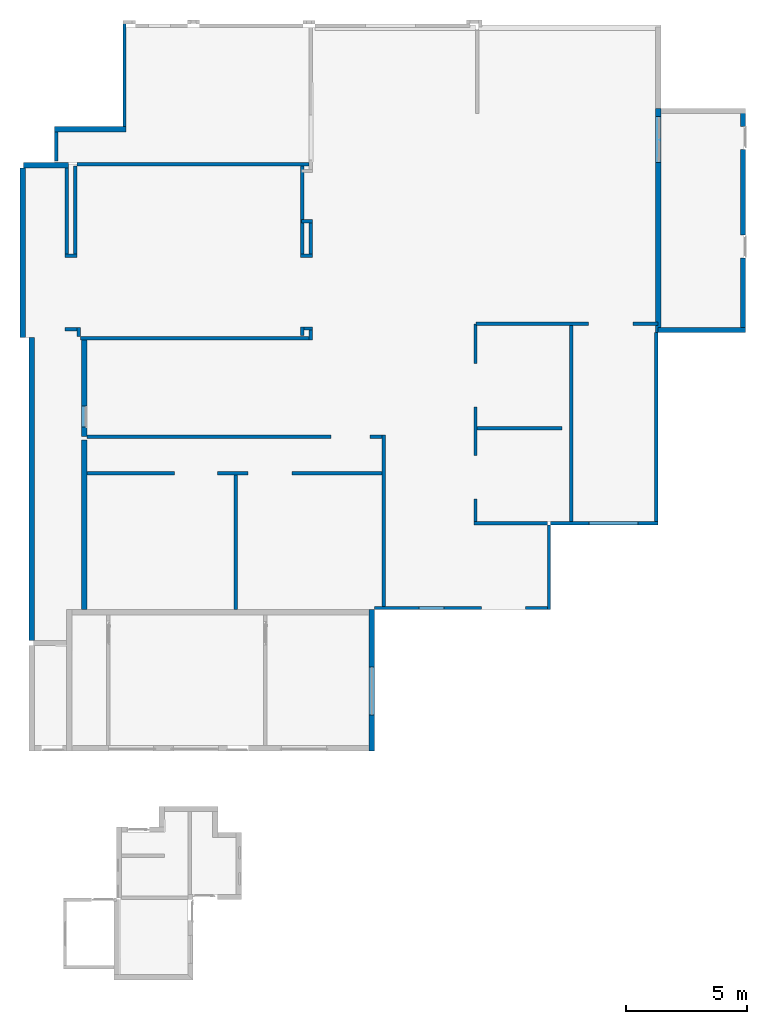
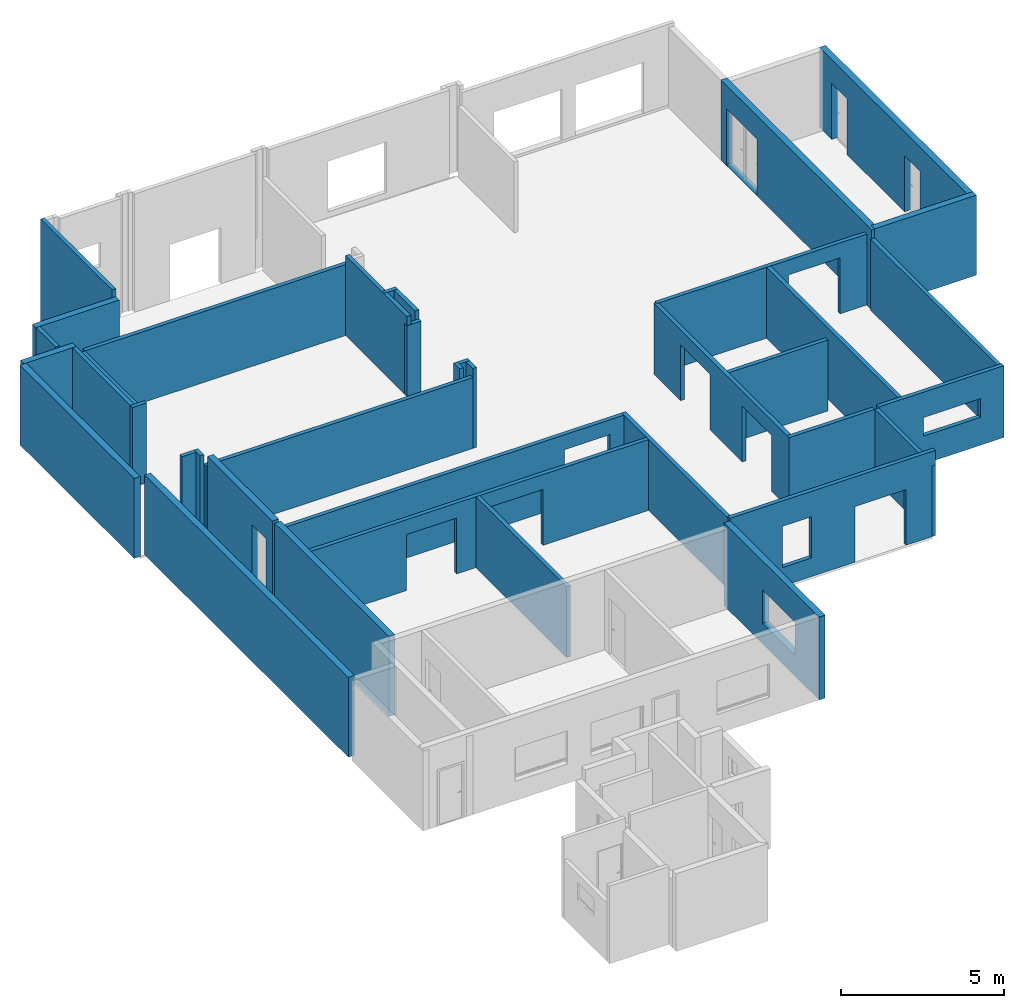
# One storey, part 2 of 4: 39 walls, 14 openings.
"""IFC4X3_ADD2 building model written with IfcOpenShell, lengths in millimetres."""

from ifc_helpers import new_model, entity, si_unit, converted_unit, frame, origin_with_axes, origin_2d_with_axis, place, context, subcontext, project, spatial, line, indexed_curve, outline, extrude, material, layer, layer_set, layer_usage, type_object, element, save


model = new_model("IFC4X3_ADD2")

# Units and contexts
model_context = context("Model", 3, precision=1e-05, world=origin_with_axes())
plan_context = context("Plan", 2, precision=1e-05, world=origin_2d_with_axis())
body_context = subcontext(model_context, "Body", "Model", "MODEL_VIEW")
ifc_project = project(units=[si_unit("VOLUMEUNIT", "CUBIC_METRE"), si_unit("LENGTHUNIT", "METRE", prefix="MILLI"), converted_unit("PLANEANGLEUNIT", "degree", entity("IfcReal", 0.0174532925199433), si_unit("PLANEANGLEUNIT", "RADIAN"), dimensions=[0, 0, 0, 0, 0, 0, 0]), si_unit("AREAUNIT", "SQUARE_METRE")], contexts=[model_context, plan_context])

# Site, building, storey
site_placement = place(None, origin_with_axes())
site = spatial("IfcSite", under=ifc_project, at=site_placement)
building_placement = place(site_placement, origin_with_axes())
building = spatial("IfcBuilding", under=site, at=building_placement, Name="Building")
storey_placement = place(building_placement, origin_with_axes())
storey = spatial("IfcBuildingStorey", under=building, at=storey_placement, Name="Storey")

# Wall, opening
ifc_material_1 = material(Name="Clay_Brick_Red", Category="Bricks")
ifc_layer_1 = layer(ifc_material_1, 220.000015258789)
ifc_layer_set_1 = layer_set([ifc_layer_1])
ifc_layer_usage_1 = layer_usage(ifc_layer_set_1, "AXIS2", "POSITIVE", 0.0)
wall_type_1 = type_object("IfcWallType", Name="220mm_External", PredefinedType="STANDARD", material=ifc_layer_set_1)
wall_1_placement = place(storey_placement, frame((14596.3191986084, 15322.7739334106, 1145.0001001358), z_axis=(0.0, 0.0, 1.0), x_axis=(6.71544341912371e-07, -0.999999999999775, 0.0)))
wall_1 = element("IfcWall", 1, at=wall_1_placement, inside=storey, type_object=wall_type_1, material=ifc_layer_usage_1, Name="Wall", context=body_context, shape_type="SweptSolid", body=[
    extrude(outline(indexed_curve([(0.0, 0.0), (0.0, 220.000015258789), (5843.0004119873, 220.000015258789), (5843.0004119873, 0.0)], segments=[line(1, 2, 3, 4, 1)])), origin_with_axes(), (0.0, 0.0, 1.0), 3107.00011253357),
])
opening_1_placement = place(wall_1_placement, frame((4350.00033728442, -79.9985116664657, 776.000022888187), z_axis=(0.0, 0.0, 1.0), x_axis=(5.52335052361657e-07, 0.999999999999847, 0.0)))
element("IfcOpeningElement", 2, at=opening_1_placement, cuts=wall_1, PredefinedType="OPENING", context=body_context, shape_type="SweptSolid", body=[
    extrude(outline(indexed_curve([(0.0, 1974.99951171875), (499.999816894531, 1974.99951171875), (499.999816894531, 0.0), (0.0, 0.0), (0.0, 1974.99951171875)])), origin_with_axes(), (0.0, 0.0, 1.0), 1252.00012207031),
])

# Wall
ifc_layer_usage_2 = layer_usage(ifc_layer_set_1, "AXIS2", "POSITIVE", 0.0)
wall_2_placement = place(storey_placement, frame((26556.3049316406, 26782.7835083008, 1145.0001001358), z_axis=(0.0, 0.0, 1.0), x_axis=(0.999999999999424, 1.07288360595641e-06, 0.0)))
element("IfcWall", 3, at=wall_2_placement, inside=storey, type_object=wall_type_1, material=ifc_layer_usage_2, Name="Wall", context=body_context, shape_type="SweptSolid", body=[
    extrude(outline(indexed_curve([(0.0, 0.0), (0.0, 220.000015258789), (3620.00012397766, 220.000015258789), (3620.00012397766, 0.0)], segments=[line(1, 2, 3, 4, 1)])), origin_with_axes(), (0.0, 0.0, 1.0), 3000.0),
])

# Wall, openings
ifc_layer_usage_3 = layer_usage(ifc_layer_set_1, "AXIS2", "POSITIVE", 0.0)
wall_3_placement = place(storey_placement, frame((30176.3038635254, 26782.7835083008, 1145.0001001358), z_axis=(0.0, 0.0, 1.0), x_axis=(-1.11659494450508e-06, 0.999999999999377, 0.0)))
wall_3 = element("IfcWall", 4, at=wall_3_placement, inside=storey, type_object=wall_type_1, material=ifc_layer_usage_3, Name="Wall", context=body_context, shape_type="SweptSolid", body=[
    extrude(outline(indexed_curve([(0.0, 0.0), (0.0, 220.000015258789), (9280.00068664551, 220.000015258789), (9280.00068664551, 0.0)], segments=[line(1, 2, 3, 4, 1)])), origin_with_axes(), (0.0, 0.0, 1.0), 3000.0),
])
opening_2_placement = place(wall_3_placement, frame((3096.27955742841, 369.999289292149, 3.10862446895044e-12), z_axis=(0.0, 0.0, 1.0), x_axis=(-1.11659494450508e-06, -0.999999999999376, 0.0)))
element("IfcOpeningElement", 5, at=opening_2_placement, cuts=wall_3, PredefinedType="OPENING", context=body_context, shape_type="SweptSolid", body=[
    extrude(outline(indexed_curve([(0.0, 0.0), (499.999908447266, 0.0), (499.999908447266, 941.722778320312), (0.0, 941.722778320312), (0.0, 0.0)])), origin_with_axes(), (0.0, 0.0, 1.0), 2100.00024414062),
])
opening_3_placement = place(wall_3_placement, frame((7580.27690239632, 369.994282483383, 3.10862446895044e-12), z_axis=(0.0, 0.0, 1.0), x_axis=(-1.11659494450508e-06, -0.999999999999376, 0.0)))
element("IfcOpeningElement", 6, at=opening_3_placement, cuts=wall_3, PredefinedType="OPENING", context=body_context, shape_type="SweptSolid", body=[
    extrude(outline(indexed_curve([(0.0, 0.0), (499.999908447266, 0.0), (499.999908447266, 941.722778320312), (0.0, 941.722778320312), (0.0, 0.0)])), origin_with_axes(), (0.0, 0.0, 1.0), 2100.00024414062),
])

# Walls
ifc_layer_usage_4 = layer_usage(ifc_layer_set_1, "AXIS2", "POSITIVE", 0.0)
wall_4_placement = place(storey_placement, frame((1587.31746673584, 35090.747833252, 1145.0001001358), z_axis=(0.0, 0.0, 1.0), x_axis=(0.999999999994429, 3.33786010740328e-06, 0.0)))
element("IfcWall", 7, at=wall_4_placement, inside=storey, type_object=wall_type_1, material=ifc_layer_usage_4, Name="Wall", context=body_context, shape_type="SweptSolid", body=[
    extrude(outline(indexed_curve([(0.0, 0.0), (0.0, 220.000015258789), (2960.00003814697, 220.000015258789), (2960.00003814697, 0.0)], segments=[line(1, 2, 3, 4, 1)])), origin_with_axes(), (0.0, 0.0, 1.0), 3000.0),
])
ifc_layer_usage_5 = layer_usage(ifc_layer_set_1, "AXIS2", "POSITIVE", 0.0)
wall_5_placement = place(storey_placement, frame((294.110298156738, 33596.7559814453, 1145.0001001358), z_axis=(0.0, 0.0, 1.0), x_axis=(0.999999999990273, 4.410743713336e-06, 0.0)))
element("IfcWall", 8, at=wall_5_placement, inside=storey, type_object=wall_type_1, material=ifc_layer_usage_5, Name="Wall", context=body_context, shape_type="SweptSolid", body=[
    extrude(outline(indexed_curve([(0.0, 0.0), (0.0, 220.000015258789), (1858.00004005432, 220.000015258789), (1858.00004005432, 0.0)], segments=[line(1, 2, 3, 4, 1)])), origin_with_axes(), (0.0, 0.0, 1.0), 3000.0),
])
ifc_layer_usage_6 = layer_usage(ifc_layer_set_1, "AXIS2", "POSITIVE", 0.0)
wall_6_placement = place(storey_placement, frame((154.110908508301, 33596.7559814453, 1145.0001001358), z_axis=(0.0, 0.0, 1.0), x_axis=(4.36703248847536e-06, -0.999999999990465, 0.0)))
element("IfcWall", 9, at=wall_6_placement, inside=storey, type_object=wall_type_1, material=ifc_layer_usage_6, Name="Wall", context=body_context, shape_type="SweptSolid", body=[
    extrude(outline(indexed_curve([(0.0, 0.0), (0.0, 220.000015258789), (7020.00045776367, 220.000015258789), (7020.00045776367, 0.0)], segments=[line(1, 2, 3, 4, 1)])), origin_with_axes(), (0.0, 0.0, 1.0), 3000.0),
])

# Wall, opening
ifc_layer_usage_7 = layer_usage(ifc_layer_set_1, "AXIS2", "POSITIVE", 0.0)
wall_7_placement = place(storey_placement, frame((2918.06888580322, 22477.7565002441, 1145.0001001358), z_axis=(0.0, 0.0, 1.0), x_axis=(-4.21603635910178e-06, 0.999999999991113, 0.0)))
wall_7 = element("IfcWall", 10, at=wall_7_placement, inside=storey, type_object=wall_type_1, material=ifc_layer_usage_7, Name="Wall", context=body_context, shape_type="SweptSolid", body=[
    extrude(outline(indexed_curve([(0.0, 0.0), (0.0, 220.000015258789), (4000.0, 220.000015258789), (4000.0, 0.0)], segments=[line(1, 2, 3, 4, 1)])), origin_with_axes(), (0.0, 0.0, 1.0), 3000.0),
])
opening_4_placement = place(wall_7_placement, frame((394.963899283713, 376.773122724019, 1.10185146331787), z_axis=(0.0, 0.0, 1.0), x_axis=(-4.21603635910178e-06, -0.999999999991112, 0.0)))
element("IfcOpeningElement", 11, at=opening_4_placement, cuts=wall_7, PredefinedType="OPENING", context=body_context, shape_type="SweptSolid", body=[
    extrude(outline(indexed_curve([(0.0, 874.999938964844), (499.999938964844, 874.999938964844), (499.999938964844, 0.0), (0.0, 0.0), (0.0, 874.999938964844)])), origin_with_axes(), (0.0, 0.0, 1.0), 2100.00024414062),
])

# Wall
ifc_layer_usage_8 = layer_usage(ifc_layer_set_1, "AXIS2", "POSITIVE", 0.0)
wall_8_placement = place(storey_placement, frame((528.263092041016, 26576.7517089844, 1145.0001001358), z_axis=(0.0, 0.0, 1.0), x_axis=(4.36703248847536e-06, -0.999999999990465, 0.0)))
element("IfcWall", 12, at=wall_8_placement, inside=storey, type_object=wall_type_1, material=ifc_layer_usage_8, Name="Wall", context=body_context, shape_type="SweptSolid", body=[
    extrude(outline(indexed_curve([(0.0, 0.0), (0.0, 220.000015258789), (12524.0001678467, 220.000015258789), (12524.0001678467, 0.0)], segments=[line(1, 2, 3, 4, 1)])), origin_with_axes(), (0.0, 0.0, 1.0), 3000.0),
])

# Wall, opening
ifc_layer_usage_9 = layer_usage(ifc_layer_set_1, "AXIS2", "POSITIVE", 0.0)
wall_9_placement = place(storey_placement, frame((26676.3153076172, 26782.7835083008, 1145.0001001358), z_axis=(0.0, 0.0, 1.0), x_axis=(-1.11659494450508e-06, 0.999999999999377, 0.0)))
wall_9 = element("IfcWall", 13, at=wall_9_placement, inside=storey, type_object=wall_type_1, material=ifc_layer_usage_9, Name="Wall", context=body_context, shape_type="SweptSolid", body=[
    extrude(outline(indexed_curve([(0.0, 0.0), (0.0, 220.000015258789), (9280.00068664551, 220.000015258789), (9280.00068664551, 0.0)], segments=[line(1, 2, 3, 4, 1)])), origin_with_axes(), (0.0, 0.0, 1.0), 3000.0),
])
opening_5_placement = place(wall_9_placement, frame((7038.99802421315, 335.002668855054, 25.0000953674316), z_axis=(0.0, 0.0, 1.0), x_axis=(-1.11659494450508e-06, -0.999999999999376, 0.0)))
element("IfcOpeningElement", 14, at=opening_5_placement, cuts=wall_9, PredefinedType="OPENING", context=body_context, shape_type="SweptSolid", body=[
    extrude(outline(indexed_curve([(0.0, 0.0), (499.999908447266, 0.0), (499.999908447266, 1903.02099609375), (0.0, 1903.02099609375), (0.0, 0.0)])), origin_with_axes(), (0.0, 0.0, 1.0), 2100.00024414062),
])

# Wall
ifc_layer_usage_10 = layer_usage(ifc_layer_set_1, "AXIS2", "POSITIVE", 0.0)
wall_10_placement = place(storey_placement, frame((2918.06888580322, 15322.7682113647, 1145.0001001358), z_axis=(0.0, 0.0, 1.0), x_axis=(-4.21603635910178e-06, 0.999999999991113, 0.0)))
element("IfcWall", 15, at=wall_10_placement, inside=storey, type_object=wall_type_1, material=ifc_layer_usage_10, Name="Wall", context=body_context, shape_type="SweptSolid", body=[
    extrude(outline(indexed_curve([(0.0, 0.0), (0.0, 220.000015258789), (7024.93484039245, 220.000015258789), (7024.93484039245, 0.0)], segments=[line(1, 2, 3, 4, 1)])), origin_with_axes(), (0.0, 0.0, 1.0), 3000.0),
])

# Wall, openings
ifc_material_2 = material(Category="Plastic")
ifc_layer_2 = layer(ifc_material_2, 140.0)
ifc_layer_set_2 = layer_set([ifc_layer_2])
ifc_layer_usage_11 = layer_usage(ifc_layer_set_2, "AXIS2", "POSITIVE", 0.0)
wall_type_2 = type_object("IfcWallType", Name="RDP", PredefinedType="ELEMENTEDWALL", material=ifc_layer_set_2)
wall_11_placement = place(storey_placement, frame((14596.3191986084, 15322.7739334106, 1145.0001001358), z_axis=(0.0, 0.0, 1.0), x_axis=(0.999999999999822, 5.960464477538e-07, 0.0)))
wall_11 = element("IfcWall", 16, at=wall_11_placement, inside=storey, type_object=wall_type_2, material=ifc_layer_usage_11, Name="Wall", context=body_context, shape_type="SweptSolid", body=[
    extrude(outline(indexed_curve([(220.000015258789, 0.0), (220.000021378385, 140.0), (7515.00058174072, 140.0), (7515.00058174072, 0.0)], segments=[line(1, 2, 3, 4, 1)])), origin_with_axes(), (0.0, 0.0, 1.0), 3200.00004768372),
])
opening_6_placement = place(wall_11_placement, frame((2072.0006763928, -110.001323820127, 702.000021934512), z_axis=(0.0, 0.0, 1.0), x_axis=(0.999999999999822, -5.960464477538e-07, 0.0)))
element("IfcOpeningElement", 17, at=opening_6_placement, cuts=wall_11, PredefinedType="OPENING", context=body_context, shape_type="SweptSolid", body=[
    extrude(outline(indexed_curve([(0.0, 499.999816894531), (1029.99951171875, 499.999816894531), (1029.99951171875, 0.0), (0.0, 0.0), (0.0, 499.999816894531)])), origin_with_axes(), (0.0, 0.0, 1.0), 1546.00012207031),
])
opening_7_placement = place(wall_11_placement, frame((5965.00054014346, -149.790936709342, 3.10862446895044e-12), z_axis=(0.0, 0.0, 1.0), x_axis=(0.999999999999822, -5.960464477538e-07, 0.0)))
element("IfcOpeningElement", 18, at=opening_7_placement, cuts=wall_11, PredefinedType="OPENING", context=body_context, shape_type="SweptSolid", body=[
    extrude(outline(indexed_curve([(-1313.99975585938, 499.999877929688), (499.999877929688, 499.999877929688), (499.999877929688, 0.0), (-1313.99975585938, 0.0), (-1313.99975585938, 499.999877929688)])), origin_with_axes(), (0.0, 0.0, 1.0), 2090.00024414062),
])

# Wall
ifc_layer_usage_12 = layer_usage(ifc_layer_set_2, "AXIS2", "POSITIVE", 0.0)
wall_12_placement = place(storey_placement, frame((22111.3204956055, 15322.7796554565, 1145.0001001358), z_axis=(0.0, 0.0, 1.0), x_axis=(-6.39757843145941e-07, 0.999999999999795, 0.0)))
element("IfcWall", 19, at=wall_12_placement, inside=storey, type_object=wall_type_2, material=ifc_layer_usage_12, Name="Wall", context=body_context, shape_type="SweptSolid", body=[
    extrude(outline(indexed_curve([(0.0, 0.0), (0.0, 140.0), (3500.00023841858, 140.0), (3500.00023841858, 0.0)], segments=[line(1, 2, 3, 4, 1)])), origin_with_axes(), (0.0, 0.0, 1.0), 2660.00008583069),
])

# Wall, opening
ifc_layer_usage_13 = layer_usage(ifc_layer_set_2, "AXIS2", "NEGATIVE", 0.0)
wall_13_placement = place(storey_placement, frame((26556.3163757324, 18822.7825164795, 1145.0001001358), z_axis=(0.0, 0.0, 1.0), x_axis=(-0.999999999999625, -8.66251525621595e-07, 0.0)))
wall_13 = element("IfcWall", 20, at=wall_13_placement, inside=storey, type_object=wall_type_2, material=ifc_layer_usage_13, Name="Wall", context=body_context, shape_type="SweptSolid", body=[
    extrude(outline(indexed_curve([(0.0, -140.0), (0.0, 0.0), (4445.00017166138, 0.0), (4445.00017166138, -140.0)], segments=[line(1, 2, 3, 4, 1)])), origin_with_axes(), (0.0, 0.0, 1.0), 2699.00012016296),
])
opening_8_placement = place(wall_13_placement, frame((1340.00123619912, 149.998457752169, -0.000119209286442157), z_axis=(0.0, 0.0, 1.0), x_axis=(-0.999999999999625, 8.66251525621595e-07, 0.0)))
element("IfcOpeningElement", 21, at=opening_8_placement, cuts=wall_13, PredefinedType="OPENING", context=body_context, shape_type="SweptSolid", body=[
    extrude(outline(indexed_curve([(-1514.00012207031, 0.0), (499.999908447266, 0.0), (499.999908447266, 499.999908447266), (-1514.00012207031, 499.999908447266), (-1514.00012207031, 0.0)])), frame((0.0, 0.0, 1050.00019073486), z_axis=(0.0, 0.0, 1.0), x_axis=(1.0, 0.0, 0.0)), (0.0, 0.0, 1.0), 699.000061035156),
])

# Walls
ifc_layer_usage_14 = layer_usage(ifc_layer_set_2, "AXIS2", "NEGATIVE", 0.0)
wall_14_placement = place(storey_placement, frame((26556.3049316406, 26782.7835083008, 1145.0001001358), z_axis=(0.0, 0.0, 1.0), x_axis=(1.5060094256097e-06, -0.999999999998866, 0.0)))
element("IfcWall", 22, at=wall_14_placement, inside=storey, type_object=wall_type_2, material=ifc_layer_usage_14, Name="Wall", context=body_context, shape_type="SweptSolid", body=[
    extrude(outline(indexed_curve([(0.0, -140.0), (0.0, 0.0), (7960.00051498413, 0.0), (7960.00051498413, -140.0)], segments=[line(1, 2, 3, 4, 1)])), origin_with_axes(), (0.0, 0.0, 1.0), 2660.00008583069),
])
ifc_layer_usage_15 = layer_usage(ifc_layer_set_2, "AXIS2", "POSITIVE", 0.0)
wall_15_placement = place(storey_placement, frame((4407.30285644531, 39700.756072998, 0.0), z_axis=(0.0, 0.0, 1.0), x_axis=(3.41335794471719e-06, -0.999999999994175, 0.0)))
element("IfcWall", 23, at=wall_15_placement, inside=storey, type_object=wall_type_2, material=ifc_layer_usage_15, Name="Wall", context=body_context, shape_type="SweptSolid", body=[
    extrude(outline(indexed_curve([(0.0, 0.0), (0.0, 140.0), (4390.00034332275, 140.0), (4390.00034332275, 0.0)], segments=[line(1, 2, 3, 4, 1)])), origin_with_axes(), (0.0, 0.0, 1.0), 4440.00005722046),
])
ifc_layer_usage_16 = layer_usage(ifc_layer_set_2, "AXIS2", "POSITIVE", 0.0)
wall_16_placement = place(storey_placement, frame((1727.33592987061, 33890.7470703125, 1145.0001001358), z_axis=(0.0, 0.0, 1.0), x_axis=(-3.38157155963813e-06, 0.999999999994283, 0.0)))
element("IfcWall", 24, at=wall_16_placement, inside=storey, type_object=wall_type_2, material=ifc_layer_usage_16, Name="Wall", context=body_context, shape_type="SweptSolid", body=[
    extrude(outline(indexed_curve([(0.0, 0.0), (0.0, 140.0), (1200.00004768372, 140.0), (1200.00004768372, 0.0)], segments=[line(1, 2, 3, 4, 1)])), origin_with_axes(), (0.0, 0.0, 1.0), 3000.0),
])
ifc_layer_usage_17 = layer_usage(ifc_layer_set_2, "AXIS2", "POSITIVE", 0.0)
wall_17_placement = place(storey_placement, frame((11807.0774078369, 31323.7533569336, 1145.0001001358), z_axis=(0.0, 0.0, 1.0), x_axis=(0.999999999993605, 3.57627868650057e-06, 0.0)))
element("IfcWall", 25, at=wall_17_placement, inside=storey, type_object=wall_type_2, material=ifc_layer_usage_17, Name="Wall", context=body_context, shape_type="SweptSolid", body=[
    extrude(outline(indexed_curve([(0.0, 0.0), (0.0, 140.0), (450.000017881393, 140.0), (450.000017881393, 0.0)], segments=[line(1, 2, 3, 4, 1)])), origin_with_axes(), (0.0, 0.0, 1.0), 3000.0),
])
ifc_layer_usage_18 = layer_usage(ifc_layer_set_2, "AXIS2", "POSITIVE", 0.0)
wall_18_placement = place(storey_placement, frame((12257.0791244507, 30037.7540588379, 1145.0001001358), z_axis=(0.0, 0.0, 1.0), x_axis=(-3.50078084918679e-06, 0.999999999993872, 0.0)))
element("IfcWall", 26, at=wall_18_placement, inside=storey, type_object=wall_type_2, material=ifc_layer_usage_18, Name="Wall", context=body_context, shape_type="SweptSolid", body=[
    extrude(outline(indexed_curve([(0.0, 0.0), (0.0, 140.0), (1426.00011825562, 140.0), (1426.00011825562, 0.0)], segments=[line(1, 2, 3, 4, 1)])), origin_with_axes(), (0.0, 0.0, 1.0), 3000.0),
])
ifc_layer_usage_19 = layer_usage(ifc_layer_set_2, "AXIS2", "POSITIVE", 0.0)
wall_19_placement = place(storey_placement, frame((12257.0791244507, 30037.7540588379, 1145.0001001358), z_axis=(0.0, 0.0, 1.0), x_axis=(-0.999999999993054, -3.72727458850162e-06, 0.0)))
element("IfcWall", 27, at=wall_19_placement, inside=storey, type_object=wall_type_2, material=ifc_layer_usage_19, Name="Wall", context=body_context, shape_type="SweptSolid", body=[
    extrude(outline(indexed_curve([(0.0, 0.0), (0.0, 140.0), (500.0, 140.0), (500.0, 0.0)], segments=[line(1, 2, 3, 4, 1)])), origin_with_axes(), (0.0, 0.0, 1.0), 2660.00008583069),
])
ifc_layer_usage_20 = layer_usage(ifc_layer_set_2, "AXIS2", "POSITIVE", 0.0)
wall_20_placement = place(storey_placement, frame((11897.0794677734, 29897.7527618408, 1145.0001001358), z_axis=(0.0, 0.0, 1.0), x_axis=(-3.85840849045819e-06, 0.999999999992556, 0.0)))
element("IfcWall", 28, at=wall_20_placement, inside=storey, type_object=wall_type_2, material=ifc_layer_usage_20, Name="Wall", context=body_context, shape_type="SweptSolid", body=[
    extrude(outline(indexed_curve([(0.0, 0.0), (0.0, 140.0), (3779.0002822876, 140.0), (3779.0002822876, 0.0)], segments=[line(1, 2, 3, 4, 1)])), origin_with_axes(), (0.0, 0.0, 1.0), 3000.0),
])
ifc_layer_usage_21 = layer_usage(ifc_layer_set_2, "AXIS2", "POSITIVE", 0.0)
wall_21_placement = place(storey_placement, frame((12117.0778274536, 33816.7572021484, 1145.0001001358), z_axis=(0.0, 0.0, 1.0), x_axis=(-0.999999999991163, -4.2041115193198e-06, 0.0)))
element("IfcWall", 29, at=wall_21_placement, inside=storey, type_object=wall_type_2, material=ifc_layer_usage_21, Name="Wall", context=body_context, shape_type="SweptSolid", body=[
    extrude(outline(indexed_curve([(0.0, 0.0), (9.40161999082785e-05, 140.0), (9604.99957074217, 140.0), (9604.99957074217, 0.0)], segments=[line(1, 2, 3, 4, 1)])), origin_with_axes(), (0.0, 0.0, 1.0), 2660.00008583069),
])
ifc_layer_usage_22 = layer_usage(ifc_layer_set_2, "AXIS2", "POSITIVE", 0.0)
wall_22_placement = place(storey_placement, frame((2512.09354400635, 29897.7546691895, 1145.0001001358), z_axis=(0.0, 0.0, 1.0), x_axis=(-3.85840849045819e-06, 0.999999999992556, 0.0)))
element("IfcWall", 30, at=wall_22_placement, inside=storey, type_object=wall_type_2, material=ifc_layer_usage_22, Name="Wall", context=body_context, shape_type="SweptSolid", body=[
    extrude(outline(indexed_curve([(0.0, 0.0), (0.0, 140.0), (3779.0002822876, 140.0), (3779.0002822876, 0.0)], segments=[line(1, 2, 3, 4, 1)])), origin_with_axes(), (0.0, 0.0, 1.0), 2660.00008583069),
])
ifc_layer_usage_23 = layer_usage(ifc_layer_set_2, "AXIS2", "POSITIVE", 0.0)
wall_23_placement = place(storey_placement, frame((2512.09259033203, 30037.7540588379, 1145.0001001358), z_axis=(0.0, 0.0, 1.0), x_axis=(-0.999999999991163, -4.2041115193198e-06, 0.0)))
element("IfcWall", 31, at=wall_23_placement, inside=storey, type_object=wall_type_2, material=ifc_layer_usage_23, Name="Wall", context=body_context, shape_type="SweptSolid", body=[
    extrude(outline(indexed_curve([(0.0, 0.0), (0.0, 140.0), (500.0, 140.0), (500.0, 0.0)], segments=[line(1, 2, 3, 4, 1)])), origin_with_axes(), (0.0, 0.0, 1.0), 3000.0),
])
ifc_layer_usage_24 = layer_usage(ifc_layer_set_2, "AXIS2", "POSITIVE", 0.0)
wall_24_placement = place(storey_placement, frame((2012.09354400635, 33596.7559814453, 1145.0001001358), z_axis=(0.0, 0.0, 1.0), x_axis=(4.36703248847536e-06, -0.999999999990465, 0.0)))
element("IfcWall", 32, at=wall_24_placement, inside=storey, type_object=wall_type_2, material=ifc_layer_usage_24, Name="Wall", context=body_context, shape_type="SweptSolid", body=[
    extrude(outline(indexed_curve([(0.0, 0.0), (0.0, 140.0), (3699.00012016296, 140.0), (3699.00012016296, 0.0)], segments=[line(1, 2, 3, 4, 1)])), origin_with_axes(), (0.0, 0.0, 1.0), 3000.0),
])
ifc_layer_usage_25 = layer_usage(ifc_layer_set_2, "AXIS2", "POSITIVE", 0.0)
wall_25_placement = place(storey_placement, frame((2512.09354400635, 26987.7548217773, 1145.0001001358), z_axis=(0.0, 0.0, 1.0), x_axis=(-0.999999999991163, -4.2041115193198e-06, 0.0)))
element("IfcWall", 33, at=wall_25_placement, inside=storey, type_object=wall_type_2, material=ifc_layer_usage_25, Name="Wall", context=body_context, shape_type="SweptSolid", body=[
    extrude(outline(indexed_curve([(0.0, 0.0), (0.0, 140.0), (500.0, 140.0), (500.0, 0.0)], segments=[line(1, 2, 3, 4, 1)])), origin_with_axes(), (0.0, 0.0, 1.0), 3000.0),
])
ifc_layer_usage_26 = layer_usage(ifc_layer_set_2, "AXIS2", "POSITIVE", 0.0)
wall_26_placement = place(storey_placement, frame((2512.09354400635, 26987.7548217773, 1145.0001001358), z_axis=(0.0, 0.0, 1.0), x_axis=(4.36703248847536e-06, -0.999999999990465, 0.0)))
element("IfcWall", 34, at=wall_26_placement, inside=storey, type_object=wall_type_2, material=ifc_layer_usage_26, Name="Wall", context=body_context, shape_type="SweptSolid", body=[
    extrude(outline(indexed_curve([(0.0, 0.0), (0.0, 140.0), (370.000004768372, 140.0), (370.000004768372, 0.0)], segments=[line(1, 2, 3, 4, 1)])), origin_with_axes(), (0.0, 0.0, 1.0), 3000.0),
])
ifc_layer_usage_27 = layer_usage(ifc_layer_set_2, "AXIS2", "POSITIVE", 0.0)
wall_27_placement = place(storey_placement, frame((12257.0791244507, 27027.8129577637, 1145.0001001358), z_axis=(0.0, 0.0, 1.0), x_axis=(-0.999999999993054, -3.72727458850162e-06, 0.0)))
element("IfcWall", 35, at=wall_27_placement, inside=storey, type_object=wall_type_2, material=ifc_layer_usage_27, Name="Wall", context=body_context, shape_type="SweptSolid", body=[
    extrude(outline(indexed_curve([(0.0, 0.0), (0.0, 140.0), (500.0, 140.0), (500.0, 0.0)], segments=[line(1, 2, 3, 4, 1)])), origin_with_axes(), (0.0, 0.0, 1.0), 3000.0),
])
ifc_layer_usage_28 = layer_usage(ifc_layer_set_2, "AXIS2", "POSITIVE", 0.0)
wall_28_placement = place(storey_placement, frame((12117.0673370361, 27027.8129577637, 1145.0001001358), z_axis=(0.0, 0.0, 1.0), x_axis=(4.36703248847536e-06, -0.999999999990465, 0.0)))
element("IfcWall", 36, at=wall_28_placement, inside=storey, type_object=wall_type_2, material=ifc_layer_usage_28, Name="Wall", context=body_context, shape_type="SweptSolid", body=[
    extrude(outline(indexed_curve([(0.0, 0.0), (0.0, 140.0), (550.000011920929, 140.0), (550.000011920929, 0.0)], segments=[line(1, 2, 3, 4, 1)])), origin_with_axes(), (0.0, 0.0, 1.0), 3000.0),
])
ifc_layer_usage_29 = layer_usage(ifc_layer_set_2, "AXIS2", "POSITIVE", 0.0)
wall_29_placement = place(storey_placement, frame((11757.0791244507, 27027.811050415, 1145.0001001358), z_axis=(0.0, 0.0, 1.0), x_axis=(4.36703248847536e-06, -0.999999999990465, 0.0)))
element("IfcWall", 37, at=wall_29_placement, inside=storey, type_object=wall_type_2, material=ifc_layer_usage_29, Name="Wall", context=body_context, shape_type="SweptSolid", body=[
    extrude(outline(indexed_curve([(0.0, 0.0), (0.0, 140.0), (366.000026464462, 140.0), (366.000026464462, 0.0)], segments=[line(1, 2, 3, 4, 1)])), origin_with_axes(), (0.0, 0.0, 1.0), 3000.0),
])
ifc_layer_usage_30 = layer_usage(ifc_layer_set_2, "AXIS2", "POSITIVE", 0.0)
wall_30_placement = place(storey_placement, frame((2652.09674835205, 26477.7565002441, 1145.0001001358), z_axis=(0.0, 0.0, 1.0), x_axis=(0.999999999990273, 4.410743713336e-06, 0.0)))
element("IfcWall", 38, at=wall_30_placement, inside=storey, type_object=wall_type_2, material=ifc_layer_usage_30, Name="Wall", context=body_context, shape_type="SweptSolid", body=[
    extrude(outline(indexed_curve([(0.0, 0.0), (0.0, 140.0), (9464.97347366499, 140.0), (9464.97346754542, 0.0)], segments=[line(1, 2, 3, 4, 1)])), origin_with_axes(), (0.0, 0.0, 1.0), 2660.00008583069),
])

# Wall, opening
ifc_layer_usage_31 = layer_usage(ifc_layer_set_2, "AXIS2", "POSITIVE", 0.0)
wall_31_placement = place(storey_placement, frame((15138.053894043, 22552.7725219727, 1145.0001001358), z_axis=(0.0, 0.0, 1.0), x_axis=(-0.999999999990132, -4.44253009841468e-06, 0.0)))
wall_31 = element("IfcWall", 39, at=wall_31_placement, inside=storey, type_object=wall_type_2, material=ifc_layer_usage_31, Name="Wall", context=body_context, shape_type="SweptSolid", body=[
    extrude(outline(indexed_curve([(0.0, 0.0), (0.0, 140.0), (12220.0155218097, 140.0), (12220.0154901005, 0.0)], segments=[line(1, 2, 3, 4, 1)])), origin_with_axes(), (0.0, 0.0, 1.0), 2660.00008583069),
])
opening_9_placement = place(wall_31_placement, frame((995.267548161694, 249.997485845061, 0.0), z_axis=(0.0, 0.0, 1.0), x_axis=(-0.999999999990132, 4.44253009841468e-06, 0.0)))
element("IfcOpeningElement", 40, at=opening_9_placement, cuts=wall_31, PredefinedType="OPENING", context=body_context, shape_type="SweptSolid", body=[
    extrude(outline(indexed_curve([(-1119.99987792969, 0.0), (499.999908447266, 0.0), (499.999908447266, 499.999908447266), (-1119.99987792969, 499.999908447266), (-1119.99987792969, 0.0)])), origin_with_axes(), (0.0, 0.0, 1.0), 2100.00024414062),
])

ifc_layer_usage_32 = layer_usage(ifc_layer_set_2, "AXIS2", "NEGATIVE", 0.0)
wall_32_placement = place(storey_placement, frame((26556.3163757324, 27081.7832946777, 1145.0001001358), z_axis=(0.0, 0.0, 1.0), x_axis=(-0.999999999999625, -8.66251525621595e-07, 0.0)))
wall_32 = element("IfcWall", 41, at=wall_32_placement, inside=storey, type_object=wall_type_2, material=ifc_layer_usage_32, Name="Wall", context=body_context, shape_type="SweptSolid", body=[
    extrude(outline(indexed_curve([(0.0, -140.0), (0.0, 0.0), (7540.00043869019, 0.0), (7540.00043869019, -140.0)], segments=[line(1, 2, 3, 4, 1)])), origin_with_axes(), (0.0, 0.0, 1.0), 2660.00008583069),
])
opening_10_placement = place(wall_32_placement, frame((1547.0009802974, 109.99927025966, 3.10862446895044e-12), z_axis=(0.0, 0.0, 1.0), x_axis=(-0.999999999999625, 8.66251525621595e-07, 0.0)))
element("IfcOpeningElement", 42, at=opening_10_placement, cuts=wall_32, PredefinedType="OPENING", context=body_context, shape_type="SweptSolid", body=[
    extrude(outline(indexed_curve([(-1330.0, 0.0), (499.999908447266, 0.0), (499.999908447266, 499.999908447266), (-1330.0, 499.999908447266), (-1330.0, 0.0)])), origin_with_axes(), (0.0, 0.0, 1.0), 2100.00024414062),
])

# Wall, openings
ifc_layer_usage_33 = layer_usage(ifc_layer_set_2, "AXIS2", "NEGATIVE", 0.0)
wall_33_placement = place(storey_placement, frame((19068.9144134521, 27142.7745819092, 1145.0001001358), z_axis=(0.0, 0.0, 1.0), x_axis=(1.26759084650883e-06, -0.999999999999197, 0.0)))
wall_33 = element("IfcWall", 43, at=wall_33_placement, inside=storey, type_object=wall_type_2, material=ifc_layer_usage_33, Name="Wall", context=body_context, shape_type="SweptSolid", body=[
    extrude(outline(indexed_curve([(0.0, -140.0), (0.0, 0.0), (8320.00064849854, 0.0), (8320.00064849854, -140.0)], segments=[line(1, 2, 3, 4, 1)])), origin_with_axes(), (0.0, 0.0, 1.0), 2660.00008583069),
])
opening_11_placement = place(wall_33_placement, frame((7246.00188583677, -302.604980119948, 3.10862446895044e-12), z_axis=(0.0, 0.0, 1.0), x_axis=(1.02917226740774e-06, 0.99999999999947, 0.0)))
element("IfcOpeningElement", 44, at=opening_11_placement, cuts=wall_33, PredefinedType="OPENING", context=body_context, shape_type="SweptSolid", body=[
    extrude(outline(indexed_curve([(0.0, 0.0), (499.999908447266, 0.0), (499.999908447266, 1812.00073242188), (0.0, 1812.00073242188), (0.0, 0.0)])), origin_with_axes(), (0.0, 0.0, 1.0), 2100.00024414062),
])
opening_12_placement = place(wall_33_placement, frame((2139.99907822229, -302.599725163461, 3.10862446895044e-12), z_axis=(0.0, 0.0, 1.0), x_axis=(1.02917226740774e-06, 0.99999999999947, 0.0)))
element("IfcOpeningElement", 45, at=opening_12_placement, cuts=wall_33, PredefinedType="OPENING", context=body_context, shape_type="SweptSolid", body=[
    extrude(outline(indexed_curve([(0.0, -1299.99987792969), (499.999908447266, -1299.99987792969), (499.999908447266, 499.999908447266), (0.0, 499.999908447266), (0.0, -1299.99987792969)])), origin_with_axes(), (0.0, 0.0, 1.0), 2100.00024414062),
])

# Walls
ifc_layer_usage_34 = layer_usage(ifc_layer_set_2, "AXIS2", "POSITIVE", 0.0)
wall_34_placement = place(storey_placement, frame((18931.3163757324, 18822.774887085, 1145.0001001358), z_axis=(0.0, 0.0, 1.0), x_axis=(0.999999999999424, 1.07288360595641e-06, 0.0)))
element("IfcWall", 46, at=wall_34_placement, inside=storey, type_object=wall_type_2, material=ifc_layer_usage_34, Name="Wall", context=body_context, shape_type="SweptSolid", body=[
    extrude(outline(indexed_curve([(0.0, 0.0), (0.0, 140.0), (3040.00020027161, 140.0), (3040.00020027161, 0.0)], segments=[line(1, 2, 3, 4, 1)])), origin_with_axes(), (0.0, 0.0, 1.0), 2660.00008583069),
])
ifc_layer_usage_35 = layer_usage(ifc_layer_set_2, "AXIS2", "NEGATIVE", 0.0)
wall_35_placement = place(storey_placement, frame((23036.3121032715, 27081.7794799805, 1145.0001001358), z_axis=(0.0, 0.0, 1.0), x_axis=(1.5060094256097e-06, -0.999999999998866, 0.0)))
element("IfcWall", 47, at=wall_35_placement, inside=storey, type_object=wall_type_2, material=ifc_layer_usage_35, Name="Wall", context=body_context, shape_type="SweptSolid", body=[
    extrude(outline(indexed_curve([(0.0, -140.0), (0.0, 0.0), (8119.0000127089, 0.0), (8118.99993983209, -140.0)], segments=[line(1, 2, 3, 4, 1)])), origin_with_axes(), (0.0, 0.0, 1.0), 2660.00008583069),
])
ifc_layer_usage_36 = layer_usage(ifc_layer_set_2, "AXIS2", "POSITIVE", 0.0)
wall_36_placement = place(storey_placement, frame((19068.9182281494, 22762.7735137939, 1145.0001001358), z_axis=(0.0, 0.0, 1.0), x_axis=(0.999999999999424, 1.07288360595641e-06, 0.0)))
element("IfcWall", 48, at=wall_36_placement, inside=storey, type_object=wall_type_2, material=ifc_layer_usage_36, Name="Wall", context=body_context, shape_type="SweptSolid", body=[
    extrude(outline(indexed_curve([(0.0, 0.0), (0.0, 140.0), (3516.00027084351, 140.0), (3516.00027084351, 0.0)], segments=[line(1, 2, 3, 4, 1)])), origin_with_axes(), (0.0, 0.0, 1.0), 2660.00008583069),
])
ifc_layer_usage_37 = layer_usage(ifc_layer_set_2, "AXIS2", "POSITIVE", 0.0)
wall_37_placement = place(storey_placement, frame((15278.0590057373, 15322.7739334106, 1145.0001001358), z_axis=(0.0, 0.0, 1.0), x_axis=(-6.39757843145941e-07, 0.999999999999795, 0.0)))
element("IfcWall", 49, at=wall_37_placement, inside=storey, type_object=wall_type_2, material=ifc_layer_usage_37, Name="Wall", context=body_context, shape_type="SweptSolid", body=[
    extrude(outline(indexed_curve([(140.0, 0.0), (140.000006119595, 140.0), (7230.00061110145, 140.0), (7230.00061110145, 0.0)], segments=[line(1, 2, 3, 4, 1)])), origin_with_axes(), (0.0, 0.0, 1.0), 2660.00008583069),
])

# Wall, openings
ifc_layer_usage_38 = layer_usage(ifc_layer_set_2, "AXIS2", "POSITIVE", 0.0)
wall_38_placement = place(storey_placement, frame((15138.0596160889, 21040.3575897217, 1145.0001001358), z_axis=(0.0, 0.0, 1.0), x_axis=(-0.999999999990132, -4.44253009841468e-06, 0.0)))
wall_38 = element("IfcWall", 50, at=wall_38_placement, inside=storey, type_object=wall_type_2, material=ifc_layer_usage_38, Name="Wall", context=body_context, shape_type="SweptSolid", body=[
    extrude(outline(indexed_curve([(0.0, 0.0), (0.0, 140.0), (12220.0002670288, 140.0), (12220.0002670288, 0.0)], segments=[line(1, 2, 3, 4, 1)])), origin_with_axes(), (0.0, 0.0, 1.0), 2660.00008583069),
])
opening_13_placement = place(wall_38_placement, frame((4240.00202492383, 399.980782197609, 0.0), z_axis=(0.0, 0.0, 1.0), x_axis=(-0.999999999990132, 4.44253009841468e-06, 0.0)))
element("IfcOpeningElement", 51, at=opening_13_placement, cuts=wall_38, PredefinedType="OPENING", context=body_context, shape_type="SweptSolid", body=[
    extrude(outline(indexed_curve([(-1309.99987792969, 0.0), (499.999908447266, 0.0), (499.999908447266, 499.999908447266), (-1309.99987792969, 499.999908447266), (-1309.99987792969, 0.0)])), origin_with_axes(), (0.0, 0.0, 1.0), 2100.00024414062),
])
opening_14_placement = place(wall_38_placement, frame((7289.99816251274, 399.967232497968, 0.0), z_axis=(0.0, 0.0, 1.0), x_axis=(-0.999999999990132, 4.44253009841468e-06, 0.0)))
element("IfcOpeningElement", 52, at=opening_14_placement, cuts=wall_38, PredefinedType="OPENING", context=body_context, shape_type="SweptSolid", body=[
    extrude(outline(indexed_curve([(-1309.99975585938, 499.999877929688), (476.000030517578, 499.999877929688), (476.000030517578, -2.03286291753898e-20), (-1309.99975585938, 0.0), (-1309.99975585938, 499.999877929688)])), origin_with_axes(), (0.0, 0.0, 1.0), 2100.00024414062),
])

# Wall
ifc_layer_usage_39 = layer_usage(ifc_layer_set_2, "AXIS2", "POSITIVE", 0.0)
wall_39_placement = place(storey_placement, frame((9148.0770111084, 15322.7682113647, 1145.0001001358), z_axis=(0.0, 0.0, 1.0), x_axis=(-4.21603635910178e-06, 0.999999999991113, 0.0)))
element("IfcWall", 53, at=wall_39_placement, inside=storey, type_object=wall_type_2, material=ifc_layer_usage_39, Name="Wall", context=body_context, shape_type="SweptSolid", body=[
    extrude(outline(indexed_curve([(0.0, 0.0), (0.0, 140.0), (5577.56464326533, 140.0), (5577.56467497445, 0.0)], segments=[line(1, 2, 3, 4, 1)])), origin_with_axes(), (0.0, 0.0, 1.0), 2660.00008583069),
])

save(model, "model.ifc")
